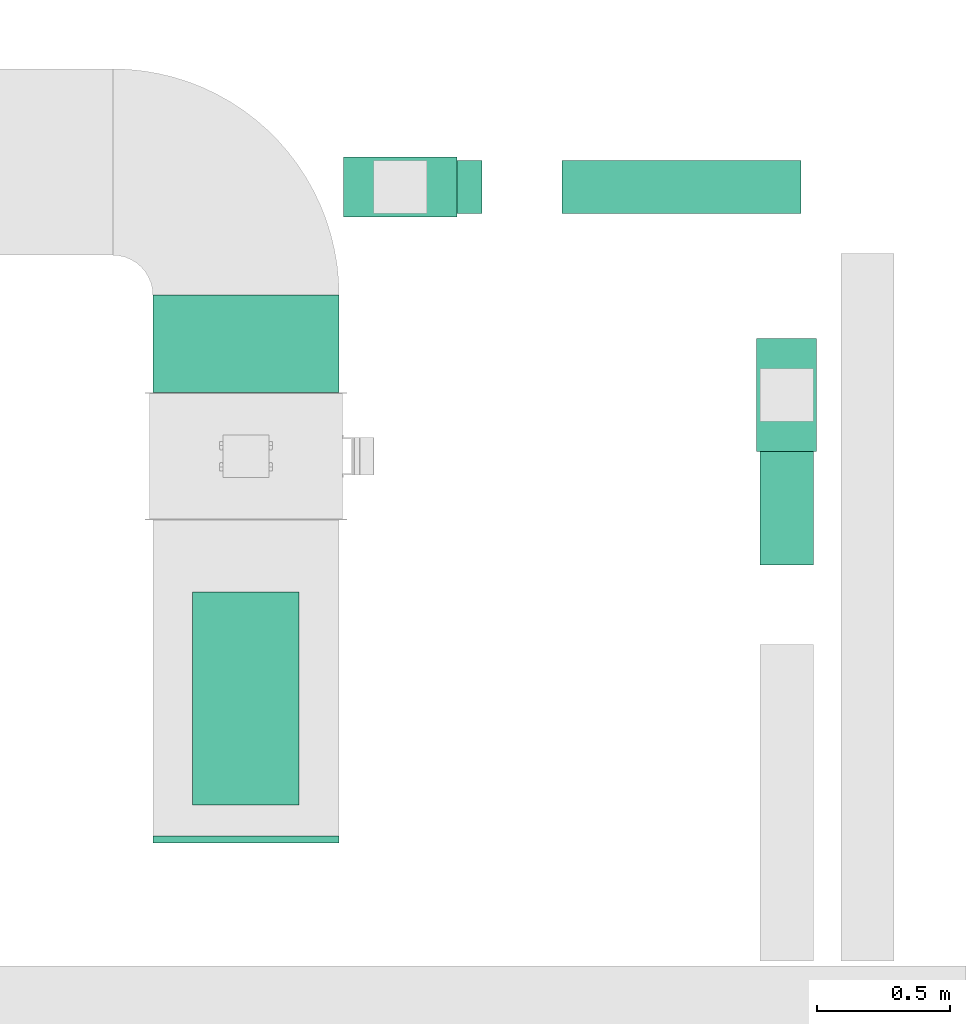
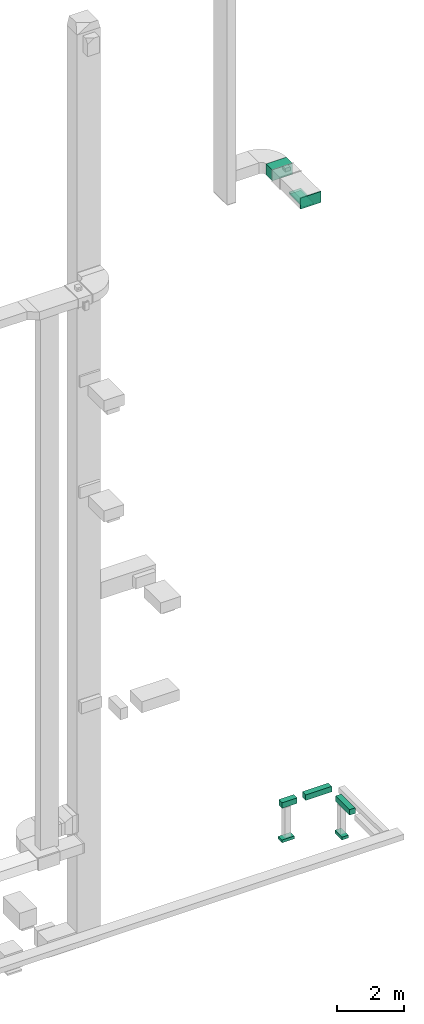
# One storey, part 16 of 25: 7 flow segments, 2 flow fittings, 1 flow terminal.
"""IFC2X3 building model written with IfcOpenShell, lengths in millimetres."""

from ifc_helpers import new_model, entity, si_unit, converted_unit, derived_unit, direction, frame, origin, origin_2d_with_axis, place, context, subcontext, project, spatial, rectangle, extrude, source, transform, mapped, material, type_object, type_shapes, element, save


model = new_model("IFC2X3")

# Units and contexts
model_context = context("Model", 3, precision=0.01, world=origin(), true_north=direction((6.12303176911189e-17, 1.0)))
body_context = subcontext(model_context, "Body", "Model", "MODEL_VIEW")
ifc_project = project(units=[si_unit("LENGTHUNIT", "METRE", prefix="MILLI"), si_unit("AREAUNIT", "SQUARE_METRE"), si_unit("VOLUMEUNIT", "CUBIC_METRE"), converted_unit("PLANEANGLEUNIT", "DEGREE", entity("IfcRatioMeasure", 0.0174532925199433), si_unit("PLANEANGLEUNIT", "RADIAN"), dimensions=[0, 0, 0, 0, 0, 0, 0]), si_unit("MASSUNIT", "GRAM", prefix="KILO"), derived_unit("MASSDENSITYUNIT", [(si_unit("MASSUNIT", "GRAM", prefix="KILO"), 1), (si_unit("LENGTHUNIT", "METRE"), -3)]), derived_unit("MOMENTOFINERTIAUNIT", [(si_unit("LENGTHUNIT", "METRE"), 4)]), si_unit("TIMEUNIT", "SECOND"), si_unit("FREQUENCYUNIT", "HERTZ"), si_unit("THERMODYNAMICTEMPERATUREUNIT", "DEGREE_CELSIUS"), derived_unit("THERMALTRANSMITTANCEUNIT", [(si_unit("MASSUNIT", "GRAM", prefix="KILO"), 1), (si_unit("THERMODYNAMICTEMPERATUREUNIT", "KELVIN"), -1), (si_unit("TIMEUNIT", "SECOND"), -3)]), derived_unit("VOLUMETRICFLOWRATEUNIT", [(si_unit("LENGTHUNIT", "METRE"), 3), (si_unit("TIMEUNIT", "SECOND"), -1)]), derived_unit("MASSFLOWRATEUNIT", [(si_unit("MASSUNIT", "GRAM", prefix="KILO"), 1), (si_unit("TIMEUNIT", "SECOND"), -1)]), derived_unit("ROTATIONALFREQUENCYUNIT", [(si_unit("TIMEUNIT", "SECOND"), -1)]), si_unit("ELECTRICCURRENTUNIT", "AMPERE"), si_unit("ELECTRICVOLTAGEUNIT", "VOLT"), si_unit("POWERUNIT", "WATT"), si_unit("FORCEUNIT", "NEWTON", prefix="KILO"), si_unit("ILLUMINANCEUNIT", "LUX"), si_unit("LUMINOUSFLUXUNIT", "LUMEN"), si_unit("LUMINOUSINTENSITYUNIT", "CANDELA"), derived_unit("USERDEFINED", [(si_unit("MASSUNIT", "GRAM", prefix="KILO"), -1), (si_unit("LENGTHUNIT", "METRE"), -2), (si_unit("TIMEUNIT", "SECOND"), 3), (si_unit("LUMINOUSFLUXUNIT", "LUMEN"), 1)]), derived_unit("LINEARVELOCITYUNIT", [(si_unit("LENGTHUNIT", "METRE"), 1), (si_unit("TIMEUNIT", "SECOND"), -1)]), si_unit("PRESSUREUNIT", "PASCAL"), derived_unit("USERDEFINED", [(si_unit("LENGTHUNIT", "METRE"), -2), (si_unit("MASSUNIT", "GRAM", prefix="KILO"), 1), (si_unit("TIMEUNIT", "SECOND"), -2)]), derived_unit("LINEARFORCEUNIT", [(si_unit("MASSUNIT", "GRAM", prefix="KILO"), 1), (si_unit("LENGTHUNIT", "METRE"), 1), (si_unit("TIMEUNIT", "SECOND"), -2), (si_unit("LENGTHUNIT", "METRE"), -1)]), derived_unit("PLANARFORCEUNIT", [(si_unit("MASSUNIT", "GRAM", prefix="KILO"), 1), (si_unit("LENGTHUNIT", "METRE"), 1), (si_unit("TIMEUNIT", "SECOND"), -2), (si_unit("LENGTHUNIT", "METRE"), -2)])], contexts=[model_context])

# Site, building, storey
site_placement = place(None, origin())
site = spatial("IfcSite", under=ifc_project, at=site_placement, CompositionType="ELEMENT")
building_placement = place(site_placement, origin())
building = spatial("IfcBuilding", under=site, at=building_placement, CompositionType="ELEMENT")
storey_placement = place(building_placement, origin())
storey = spatial("IfcBuildingStorey", under=building, at=storey_placement, CompositionType="ELEMENT", Elevation=0.0)

# Flow segments
duct_segment_type = type_object("IfcDuctSegmentType", PredefinedType="NOTDEFINED")
flow_segment_1_placement = place(storey_placement, frame((69919.9, 9984.97, 22730.0)))
element("IfcFlowSegment", 1, at=flow_segment_1_placement, inside=storey, type_object=duct_segment_type, context=body_context, shape_type="SweptSolid", body=[
    extrude(rectangle(XDim=800.0, YDim=400.000000000004, at=origin_2d_with_axis()), frame((200.0, 400.0, 0.0), z_axis=(0.0, 0.0, 1.0), x_axis=(0.0, 1.0, 0.0)), (0.0, 0.0, 1.0), 50.000000000006),
])
flow_segment_2_placement = place(storey_placement, frame((69769.9, 11535.0, 22800.0)))
element("IfcFlowSegment", 2, at=flow_segment_2_placement, inside=storey, type_object=duct_segment_type, context=body_context, shape_type="SweptSolid", body=[
    extrude(rectangle(XDim=364.595053180721, YDim=699.999999999997, at=origin_2d_with_axis()), frame((350.0, 182.3, 0.0), z_axis=(0.0, 0.0, 1.0), x_axis=(0.0, -1.0, 0.0)), (0.0, 0.0, 1.0), 399.999999999996),
])
flow_segment_3_placement = place(storey_placement, frame((72050.46, 10887.26, -650.0)))
element("IfcFlowSegment", 3, at=flow_segment_3_placement, inside=storey, type_object=duct_segment_type, context=body_context, shape_type="SweptSolid", body=[
    extrude(rectangle(XDim=834.396194023908, YDim=199.999999999998, at=origin_2d_with_axis()), frame((100.0, 417.2, 0.0), z_axis=(0.0, 0.0, 1.0), x_axis=(0.0, 1.0, 0.0)), (0.0, 0.0, 1.0), 200.0),
])
flow_segment_4_placement = place(storey_placement, frame((70499.23, 12205.5, -650.0)))
element("IfcFlowSegment", 4, at=flow_segment_4_placement, inside=storey, type_object=duct_segment_type, context=body_context, shape_type="SweptSolid", body=[
    extrude(rectangle(XDim=507.012116293382, YDim=200.0, at=origin_2d_with_axis()), frame((253.51, 100.0, 0.0), z_axis=(0.0, 0.0, 1.0), x_axis=(-1.0, 0.0, 0.0)), (0.0, 0.0, 1.0), 200.0),
])
flow_segment_5_placement = place(storey_placement, frame((71306.25, 12205.5, -650.0)))
element("IfcFlowSegment", 5, at=flow_segment_5_placement, inside=storey, type_object=duct_segment_type, context=body_context, shape_type="SweptSolid", body=[
    extrude(rectangle(XDim=898.086611318234, YDim=200.0, at=origin_2d_with_axis()), frame((449.04, 100.0, 0.0), z_axis=(0.0, 0.0, 1.0), x_axis=(-1.0, 0.0, 0.0)), (0.0, 0.0, 1.0), 200.0),
])
flow_segment_6_placement = place(storey_placement, frame((72037.96, 11312.4, -1800.0)))
element("IfcFlowSegment", 6, at=flow_segment_6_placement, inside=storey, type_object=duct_segment_type, context=body_context, shape_type="SweptSolid", body=[
    extrude(rectangle(XDim=425.000000000007, YDim=225.000000000001, at=origin_2d_with_axis()), frame((112.5, 212.5, 0.0), z_axis=(0.0, 0.0, 1.0), x_axis=(0.0, -1.0, 0.0)), (0.0, 0.0, 1.0), 100.0),
])
flow_segment_7_placement = place(storey_placement, frame((70486.73, 12193.0, -1894.0)))
element("IfcFlowSegment", 7, at=flow_segment_7_placement, inside=storey, type_object=duct_segment_type, context=body_context, shape_type="SweptSolid", body=[
    extrude(rectangle(XDim=425.000000000007, YDim=225.000000000001, at=origin_2d_with_axis()), frame((212.5, 112.5, 0.0)), (0.0, 0.0, 1.0), 100.0),
])

# Flow fitting
ifc_material_1 = material()
duct_fitting_type_1 = type_object("IfcDuctFittingType", PredefinedType="NOTDEFINED", material=ifc_material_1)
shared_shape_1 = source(origin(), body_context, "Body", "SweptSolid", [
    extrude(rectangle(XDim=24.9999999999999, YDim=700.0, at=origin_2d_with_axis()), frame((12.5, 0.0, -200.0)), (0.0, 0.0, 1.0), 400.0),
])
type_shapes(duct_fitting_type_1, [shared_shape_1])
flow_fitting_1_placement = place(storey_placement, frame((70119.9, 9867.9, 23000.0), z_axis=(0.0, 0.0, 1.0), x_axis=(0.0, -1.0, 0.0)))
element("IfcFlowFitting", 8, at=flow_fitting_1_placement, inside=storey, type_object=duct_fitting_type_1, material=ifc_material_1, context=body_context, shape_type="MappedRepresentation", body=[
    mapped(shared_shape_1, transform((0.0, 0.0, 0.0), scale=1.0)),
])

# Flow terminal
ifc_material_2 = material()
air_terminal_type = type_object("IfcAirTerminalType", PredefinedType="NOTDEFINED", material=ifc_material_2)
shared_shape_2 = source(origin(), body_context, "Body", "SweptSolid", [
    extrude(rectangle(XDim=4.0, YDim=799.999999999999, at=origin_2d_with_axis()), frame((0.0, -2.0, -200.0), z_axis=(0.0, 0.0, 1.0), x_axis=(0.0, 1.0, 0.0)), (0.0, 0.0, 1.0), 400.000000000005),
])
type_shapes(air_terminal_type, [shared_shape_2])
flow_terminal_placement = place(storey_placement, frame((70119.9, 10384.97, 22730.0), z_axis=(1.0, 0.0, 0.0), x_axis=(0.0, 1.0, 0.0)))
element("IfcFlowTerminal", 9, at=flow_terminal_placement, inside=storey, type_object=air_terminal_type, material=ifc_material_2, context=body_context, shape_type="MappedRepresentation", body=[
    mapped(shared_shape_2, transform((0.0, 0.0, 0.0), scale=1.0)),
])

# Flow fitting
duct_fitting_type_2 = type_object("IfcDuctFittingType", PredefinedType="NOTDEFINED", material=ifc_material_1)
shared_shape_3 = source(origin(), body_context, "Body", "SweptSolid", [
    extrude(rectangle(XDim=400.0, YDim=26.0960000000022, at=origin_2d_with_axis()), frame((6.95, 0.0, -400.0), z_axis=(0.0, 0.0, 1.0), x_axis=(0.0, -1.0, 0.0)), (0.0, 0.0, 1.0), 800.0),
])
type_shapes(duct_fitting_type_2, [shared_shape_3])
flow_fitting_2_placement = place(storey_placement, frame((70119.9, 10384.97, 22800.0), z_axis=(0.0, -1.0, 0.0), x_axis=(0.0, 0.0, -1.0)))
element("IfcFlowFitting", 10, at=flow_fitting_2_placement, inside=storey, type_object=duct_fitting_type_2, material=ifc_material_1, context=body_context, shape_type="MappedRepresentation", body=[
    mapped(shared_shape_3, transform((0.0, 0.0, 0.0), scale=1.0)),
])

save(model, "model.ifc")
